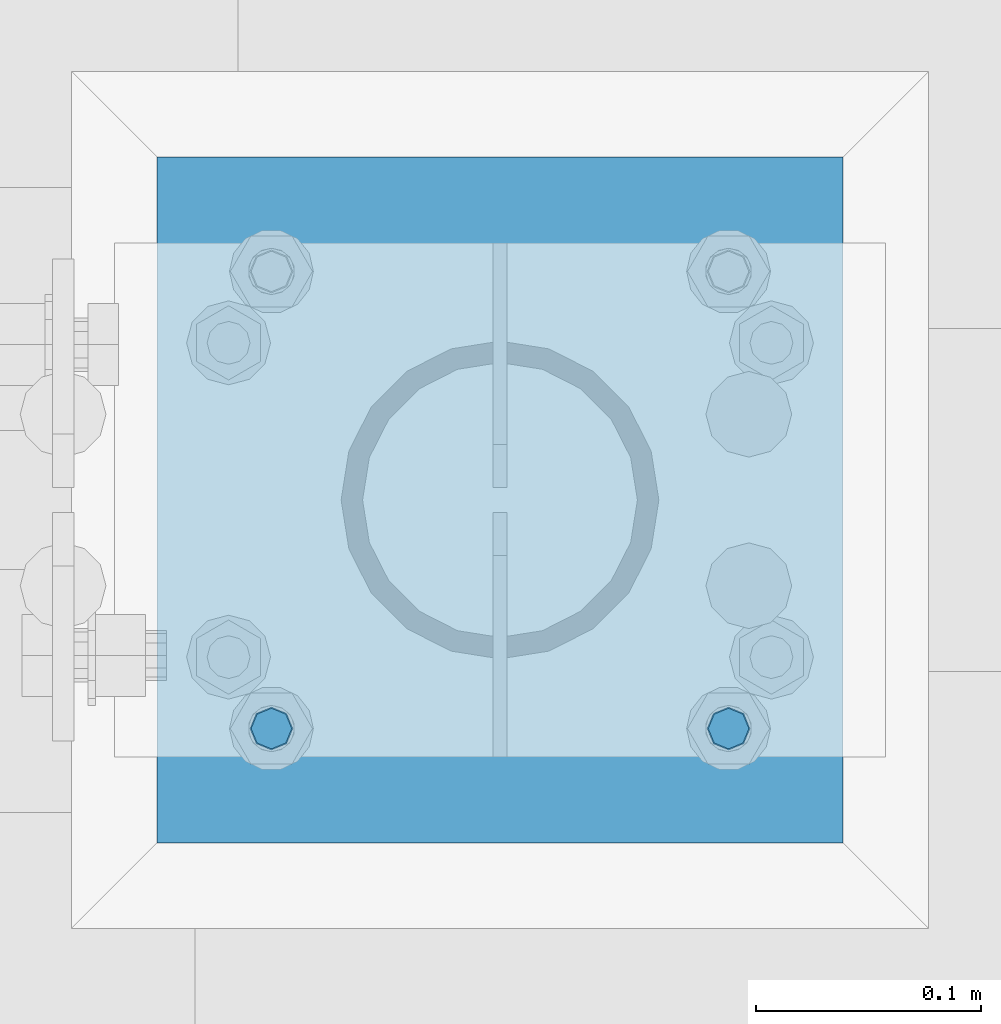
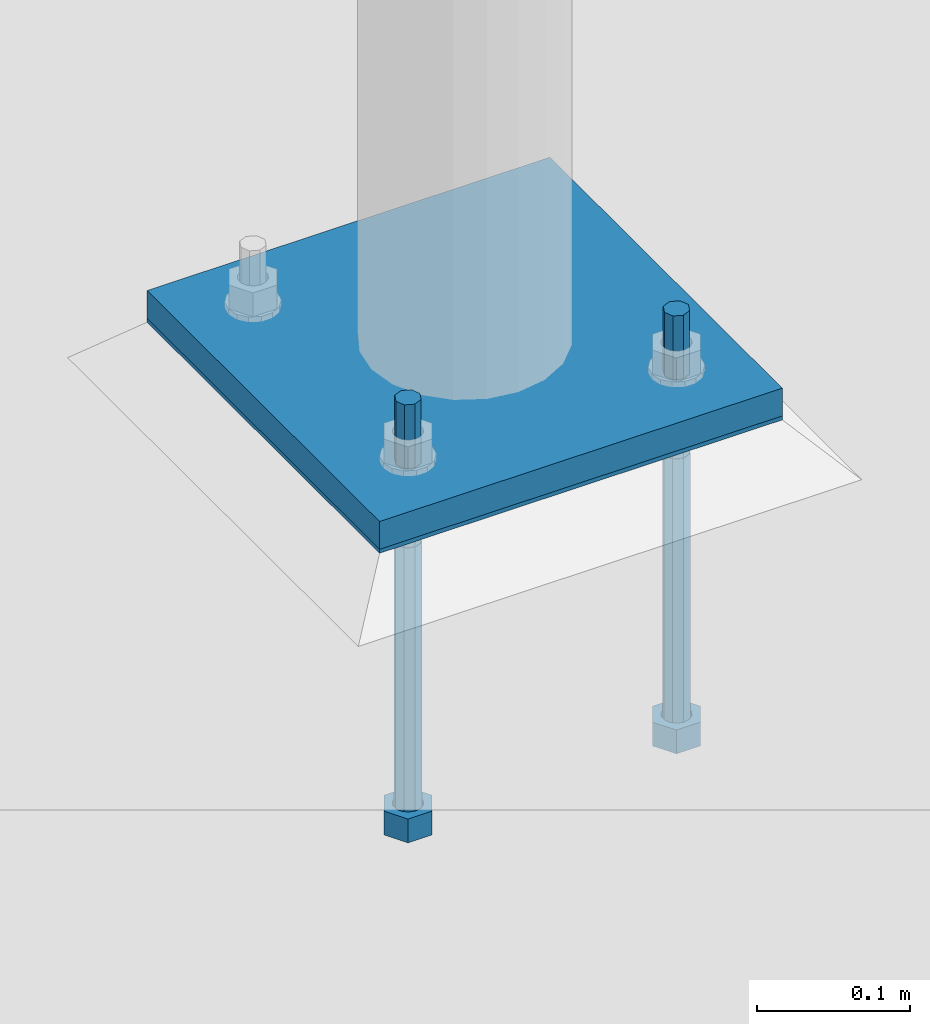
# One storey, part 388 of 975: 4 beams.
"""IFC2X3 building model written with IfcOpenShell, lengths in millimetres."""

from ifc_helpers import new_model, si_unit, frame, origin_with_axes, place, context, subcontext, project, spatial, faceted_brep, material, type_object, element, save


model = new_model("IFC2X3")

# Units and contexts
model_context = context("Model", 3, precision=1e-05, world=origin_with_axes())
body_context = subcontext(model_context, "Body", "Model", "MODEL_VIEW")
ifc_project = project(units=[si_unit("LENGTHUNIT", "METRE", prefix="MILLI"), si_unit("AREAUNIT", "SQUARE_METRE"), si_unit("VOLUMEUNIT", "CUBIC_METRE"), si_unit("MASSUNIT", "GRAM", prefix="KILO"), si_unit("TIMEUNIT", "SECOND"), si_unit("PLANEANGLEUNIT", "RADIAN"), si_unit("SOLIDANGLEUNIT", "STERADIAN"), si_unit("THERMODYNAMICTEMPERATUREUNIT", "DEGREE_CELSIUS"), si_unit("LUMINOUSINTENSITYUNIT", "LUMEN")], contexts=[model_context])

# Site, building, storey
site_placement = place(None, origin_with_axes())
site = spatial("IfcSite", under=ifc_project, at=site_placement, CompositionType="ELEMENT")
building_placement = place(site_placement, origin_with_axes())
building = spatial("IfcBuilding", under=site, at=building_placement, Name="Undefined", CompositionType="ELEMENT")
storey_placement = place(building_placement, origin_with_axes())
storey = spatial("IfcBuildingStorey", under=building, at=storey_placement, Name="Undefined", CompositionType="ELEMENT", Elevation=0.0)

# Beams
ifc_material_1 = material(Name="STEEL/F1554-36")
beam_type_1 = type_object("IfcBeamType", PredefinedType="NOTDEFINED")
beam_1_placement = place(storey_placement, frame((4375.15000152588, 5718.17500305176, -304.799999999999), z_axis=(0.0, -1.0, 0.0), x_axis=(0.0, 0.0, -1.0)))
element("IfcBeam", 1, at=beam_1_placement, inside=storey, type_object=beam_type_1, material=ifc_material_1, Name="HEADED_ANCHOR_BOLT", context=body_context, shape_type="Brep", body=[
    faceted_brep([(210.34375, -9.13000011444637, 15.8100004196167), (210.34375, -18.2600002288873, 0.0), (229.393749999999, -18.2600002288873, 0.0), (229.393749999999, -9.13000011444637, 15.8100004196167), (210.34375, 9.13000011443546, 15.8100004196167), (229.393749999999, 9.13000011443546, 15.8100004196167), (210.34375, 18.2600002288764, 0.0), (229.393749999999, 18.2600002288764, 0.0), (210.34375, 9.13000011443546, -15.8100004196167), (229.393749999999, 9.13000011443546, -15.8100004196167), (210.34375, -9.13000011444637, -15.8100004196167), (229.393749999999, -9.13000011444637, -15.8100004196167), (210.34375, -4.47768005528815, 9.29799844179888), (210.34375, -8.06850066047991, 6.43441456490837), (210.34375, -10.0612557561972, 2.29641597052159), (210.34375, -10.0612557561972, -2.29641597052159), (210.34375, -8.06850066047991, -6.43441456490837), (210.34375, -4.47768005528815, -9.29799844179888), (210.34375, -5.45696821063757e-12, -10.3199996948242), (210.34375, 4.47768005527723, -9.29799844179888), (210.34375, 8.068500660469, -6.43441456490837), (210.34375, 10.0612557561863, -2.29641597052159), (210.34375, 10.0612557561863, 2.29641597052159), (210.34375, 8.068500660469, 6.43441456490837), (210.34375, 4.47768005527723, 9.29799844179888), (210.34375, -5.45696821063757e-12, 10.3199996948242), (229.393749999999, -5.45696821063757e-12, 10.3199996948242), (229.393749999999, -4.47768005528815, 9.29799844179888), (229.393749999999, -8.06850066047991, 6.43441456490837), (229.393749999999, -10.0612557561972, 2.29641597052159), (229.393749999999, -10.0612557561972, -2.29641597052159), (229.393749999999, -8.06850066047991, -6.43441456490837), (229.393749999999, -4.47768005528815, -9.29799844179888), (229.393749999999, -5.45696821063757e-12, -10.3199996948242), (229.393749999999, 4.47768005527723, -9.29799844179888), (229.393749999999, 8.068500660469, -6.43441456490837), (229.393749999999, 10.0612557561863, -2.29641597052159), (229.393749999999, 10.0612557561863, 2.29641597052159), (229.393749999999, 8.068500660469, 6.43441456490837), (229.393749999999, 4.47768005527723, 9.29799844179888), (0.0, -6.73519209080223, 6.73519209080186), (0.0, -9.52499999999964, 0.0), (228.6, -9.52500000000146, 0.0), (228.6, -6.73519209080405, 6.73519209080223), (-9.87109982941227e-13, -1.20792265079217e-13, 9.52499961853027), (228.6, 0.0, 9.52499999999964), (0.0, 6.73519209080223, 6.73519209080186), (228.6, 6.73519209080405, 6.73519209080223), (0.0, 9.52499999999964, 0.0), (228.6, 9.52500000000146, 0.0), (0.0, 6.73519209080223, -6.73519209080186), (228.6, 6.73519209080405, -6.73519209080223), (2.95075507493764e-12, -1.20792265079217e-13, -9.52499961853027), (228.6, 0.0, -9.52499999999964), (-114.293750057273, -6.36396001342564, 6.36396103067909), (-114.293749999997, 1.01725345302839e-06, 9.0), (-114.293749942721, 6.36396204793255, 6.36396103067909), (-114.293749918997, 9.00000101725345, 0.0), (-114.293749942721, 6.36396204793255, -6.36396103067909), (-114.293749999997, 1.01725345302839e-06, -9.0), (-114.293750057273, -6.36396001342564, -6.36396103067909), (-114.293750080997, -8.99999898274655, 0.0), (0.00625005727778216, 6.36396101919127, -6.36396103067909), (0.00625000000218279, -1.14878275780939e-08, -9.0), (0.00624994272658341, -6.36396104216692, -6.36396103067909), (0.00624991900230043, -9.00000001148783, 0.0), (0.00624994272658341, -6.36396104216692, 6.36396103067909), (0.00625000000218279, -1.14878275780939e-08, 9.0), (0.00625005727778216, 6.36396101919127, 6.36396103067909), (0.00625008100212199, 8.99999998851217, 0.0), (0.0, -6.73519209080223, -6.73519209080186), (228.6, -6.73519209080405, -6.73519209080223)], [[[0, 1, 2, 3]], [[4, 0, 3, 5]], [[6, 4, 5, 7]], [[8, 6, 7, 9]], [[10, 8, 9, 11]], [[0, 4, 6, 8, 10, 1], [12, 13, 14, 15, 16, 17, 18, 19, 20, 21, 22, 23, 24, 25]], [[12, 25, 26, 27]], [[13, 12, 27, 28]], [[14, 13, 28, 29]], [[15, 14, 29, 30]], [[16, 15, 30, 31]], [[17, 16, 31, 32]], [[18, 17, 32, 33]], [[19, 18, 33, 34]], [[20, 19, 34, 35]], [[21, 20, 35, 36]], [[22, 21, 36, 37]], [[23, 22, 37, 38]], [[24, 23, 38, 39]], [[25, 24, 39, 26]], [[9, 7, 5, 3, 2, 11], [38, 37, 36, 35, 34, 33, 32, 31, 30, 29, 28, 27, 26, 39]], [[1, 10, 11, 2]], [[40, 41, 42, 43]], [[44, 40, 43, 45]], [[46, 44, 45, 47]], [[48, 46, 47, 49]], [[50, 48, 49, 51]], [[52, 50, 51, 53]], [[54, 55, 56, 57, 58, 59, 60, 61]], [[59, 58, 62, 63]], [[60, 59, 63, 64]], [[61, 60, 64, 65]], [[54, 61, 65, 66]], [[55, 54, 66, 67]], [[56, 55, 67, 68]], [[57, 56, 68, 69]], [[58, 57, 69, 62]], [[40, 44, 46, 48, 50, 52, 70, 41], [68, 67, 66, 65, 64, 63, 62, 69]], [[41, 70, 71, 42]], [[53, 51, 49, 47, 45, 43, 42, 71]], [[70, 52, 53, 71]]]),
])
beam_2_placement = place(storey_placement, frame((4578.34999847412, 5718.17500305176, -304.799999999999), z_axis=(0.0, -1.0, 0.0), x_axis=(0.0, 0.0, -1.0)))
element("IfcBeam", 2, at=beam_2_placement, inside=storey, type_object=beam_type_1, material=ifc_material_1, Name="HEADED_ANCHOR_BOLT", context=body_context, shape_type="Brep", body=[
    faceted_brep([(210.34375, -9.13000011444637, 15.8100004196167), (210.34375, -18.2600002288873, 0.0), (229.393749999999, -18.2600002288873, 0.0), (229.393749999999, -9.13000011444637, 15.8100004196167), (210.34375, 9.13000011443546, 15.8100004196167), (229.393749999999, 9.13000011443546, 15.8100004196167), (210.34375, 18.2600002288764, 0.0), (229.393749999999, 18.2600002288764, 0.0), (210.34375, 9.13000011443546, -15.8100004196167), (229.393749999999, 9.13000011443546, -15.8100004196167), (210.34375, -9.13000011444637, -15.8100004196167), (229.393749999999, -9.13000011444637, -15.8100004196167), (210.34375, -4.47768005528815, 9.29799844179888), (210.34375, -8.06850066047991, 6.43441456490837), (210.34375, -10.0612557561972, 2.29641597052159), (210.34375, -10.0612557561972, -2.29641597052159), (210.34375, -8.06850066047991, -6.43441456490837), (210.34375, -4.47768005528815, -9.29799844179888), (210.34375, -5.45696821063757e-12, -10.3199996948242), (210.34375, 4.47768005527723, -9.29799844179888), (210.34375, 8.068500660469, -6.43441456490837), (210.34375, 10.0612557561863, -2.29641597052159), (210.34375, 10.0612557561863, 2.29641597052159), (210.34375, 8.068500660469, 6.43441456490837), (210.34375, 4.47768005527723, 9.29799844179888), (210.34375, -5.45696821063757e-12, 10.3199996948242), (229.393749999999, -5.45696821063757e-12, 10.3199996948242), (229.393749999999, -4.47768005528815, 9.29799844179888), (229.393749999999, -8.06850066047991, 6.43441456490837), (229.393749999999, -10.0612557561972, 2.29641597052159), (229.393749999999, -10.0612557561972, -2.29641597052159), (229.393749999999, -8.06850066047991, -6.43441456490837), (229.393749999999, -4.47768005528815, -9.29799844179888), (229.393749999999, -5.45696821063757e-12, -10.3199996948242), (229.393749999999, 4.47768005527723, -9.29799844179888), (229.393749999999, 8.068500660469, -6.43441456490837), (229.393749999999, 10.0612557561863, -2.29641597052159), (229.393749999999, 10.0612557561863, 2.29641597052159), (229.393749999999, 8.068500660469, 6.43441456490837), (229.393749999999, 4.47768005527723, 9.29799844179888), (0.0, -6.73519209080223, 6.73519209080186), (0.0, -9.52499999999964, 0.0), (228.6, -9.52500000000146, 0.0), (228.6, -6.73519209080405, 6.73519209080223), (-9.87109982941227e-13, -1.20792265079217e-13, 9.52499961853027), (228.6, 0.0, 9.52499999999964), (0.0, 6.73519209080223, 6.73519209080186), (228.6, 6.73519209080405, 6.73519209080223), (0.0, 9.52499999999964, 0.0), (228.6, 9.52500000000146, 0.0), (0.0, 6.73519209080223, -6.73519209080186), (228.6, 6.73519209080405, -6.73519209080223), (2.95075507493764e-12, -1.20792265079217e-13, -9.52499961853027), (228.6, 0.0, -9.52499999999964), (-114.293750057273, -6.36396001342564, 6.36396103067909), (-114.293749999997, 1.01725345302839e-06, 9.0), (-114.293749942721, 6.36396204793255, 6.36396103067909), (-114.293749918997, 9.00000101725345, 0.0), (-114.293749942721, 6.36396204793255, -6.36396103067909), (-114.293749999997, 1.01725345302839e-06, -9.0), (-114.293750057273, -6.36396001342564, -6.36396103067909), (-114.293750080997, -8.99999898274655, 0.0), (0.00625005727778216, 6.36396101919127, -6.36396103067909), (0.00625000000218279, -1.14878275780939e-08, -9.0), (0.00624994272658341, -6.36396104216692, -6.36396103067909), (0.00624991900230043, -9.00000001148783, 0.0), (0.00624994272658341, -6.36396104216692, 6.36396103067909), (0.00625000000218279, -1.14878275780939e-08, 9.0), (0.00625005727778216, 6.36396101919127, 6.36396103067909), (0.00625008100212199, 8.99999998851217, 0.0), (0.0, -6.73519209080223, -6.73519209080186), (228.6, -6.73519209080405, -6.73519209080223)], [[[0, 1, 2, 3]], [[4, 0, 3, 5]], [[6, 4, 5, 7]], [[8, 6, 7, 9]], [[10, 8, 9, 11]], [[0, 4, 6, 8, 10, 1], [12, 13, 14, 15, 16, 17, 18, 19, 20, 21, 22, 23, 24, 25]], [[12, 25, 26, 27]], [[13, 12, 27, 28]], [[14, 13, 28, 29]], [[15, 14, 29, 30]], [[16, 15, 30, 31]], [[17, 16, 31, 32]], [[18, 17, 32, 33]], [[19, 18, 33, 34]], [[20, 19, 34, 35]], [[21, 20, 35, 36]], [[22, 21, 36, 37]], [[23, 22, 37, 38]], [[24, 23, 38, 39]], [[25, 24, 39, 26]], [[9, 7, 5, 3, 2, 11], [38, 37, 36, 35, 34, 33, 32, 31, 30, 29, 28, 27, 26, 39]], [[1, 10, 11, 2]], [[40, 41, 42, 43]], [[44, 40, 43, 45]], [[46, 44, 45, 47]], [[48, 46, 47, 49]], [[50, 48, 49, 51]], [[52, 50, 51, 53]], [[54, 55, 56, 57, 58, 59, 60, 61]], [[59, 58, 62, 63]], [[60, 59, 63, 64]], [[61, 60, 64, 65]], [[54, 61, 65, 66]], [[55, 54, 66, 67]], [[56, 55, 67, 68]], [[57, 56, 68, 69]], [[58, 57, 69, 62]], [[40, 44, 46, 48, 50, 52, 70, 41], [68, 67, 66, 65, 64, 63, 62, 69]], [[41, 70, 71, 42]], [[53, 51, 49, 47, 45, 43, 42, 71]], [[70, 52, 53, 71]]]),
])
ifc_material_2 = material(Name="STEEL/A36")
beam_type_2 = type_object("IfcBeamType", PredefinedType="NOTDEFINED")
beam_3_placement = place(storey_placement, frame((4476.75, 5667.375, -265.112500000001), z_axis=(-0.999999999999998, 6.90000001668524e-08, 0.0), x_axis=(0.0, 1.0, 0.0)))
element("IfcBeam", 3, at=beam_3_placement, inside=storey, type_object=beam_type_2, material=ifc_material_2, Name="TEMPLATE", context=body_context, shape_type="Brep", body=[
    faceted_brep([(0.0, 1.58750000000009, -152.4), (0.0, 1.58750000000009, 152.4), (304.799999999153, 1.58750000000001, 152.400000000001), (304.799999999153, 1.58750000000001, -152.400000000001), (0.0, -1.58750000000009, 152.4), (304.799999999153, -1.58750000000001, 152.400000000001), (0.0, -1.58750000000009, -152.4), (304.799999999153, -1.58750000000001, -152.400000000001)], [[[0, 1, 2, 3]], [[1, 4, 5, 2]], [[4, 6, 7, 5]], [[6, 0, 3, 7]], [[5, 7, 3, 2]], [[6, 4, 1, 0]]]),
])
beam_type_3 = type_object("IfcBeamType", PredefinedType="NOTDEFINED")
beam_4_placement = place(storey_placement, frame((4476.75, 5667.375, -254.0), z_axis=(-0.999999999999998, 6.90000001668524e-08, 0.0), x_axis=(0.0, 1.0, 0.0)))
element("IfcBeam", 4, at=beam_4_placement, inside=storey, type_object=beam_type_3, material=ifc_material_2, Name="PLATE", context=body_context, shape_type="Brep", body=[
    faceted_brep([(0.0, 12.7, -152.400000000001), (-1.36424205265939e-12, 12.7, 152.400009155273), (304.800000000003, 12.7, 152.400000000001), (304.800000000003, 12.7, -152.400000000001), (0.0, -12.7, 152.400000000001), (304.800000000003, -12.7, 152.400000000001), (0.0, -12.7, -152.400000000001), (304.800000000003, -12.7, -152.400000000001)], [[[0, 1, 2, 3]], [[1, 4, 5, 2]], [[4, 6, 7, 5]], [[6, 0, 3, 7]], [[5, 7, 3, 2]], [[6, 4, 1, 0]]]),
])

save(model, "model.ifc")
